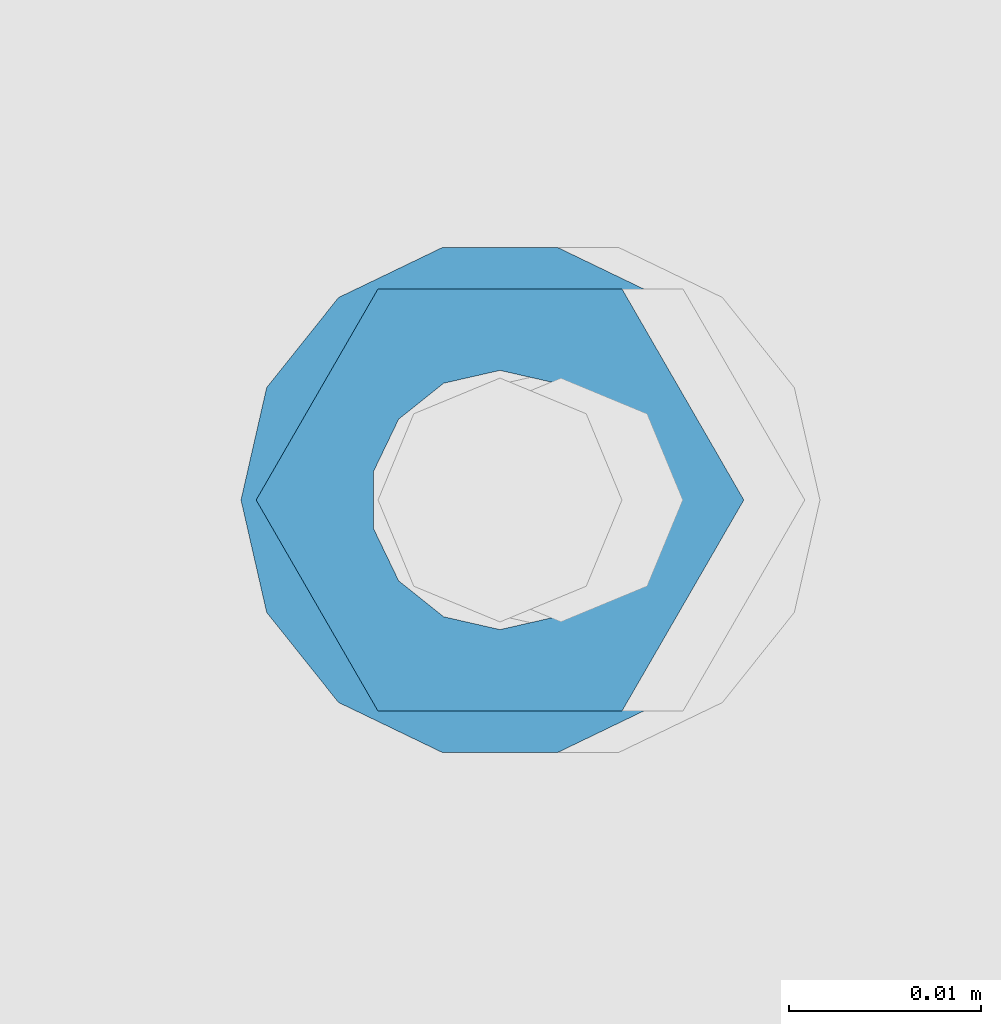
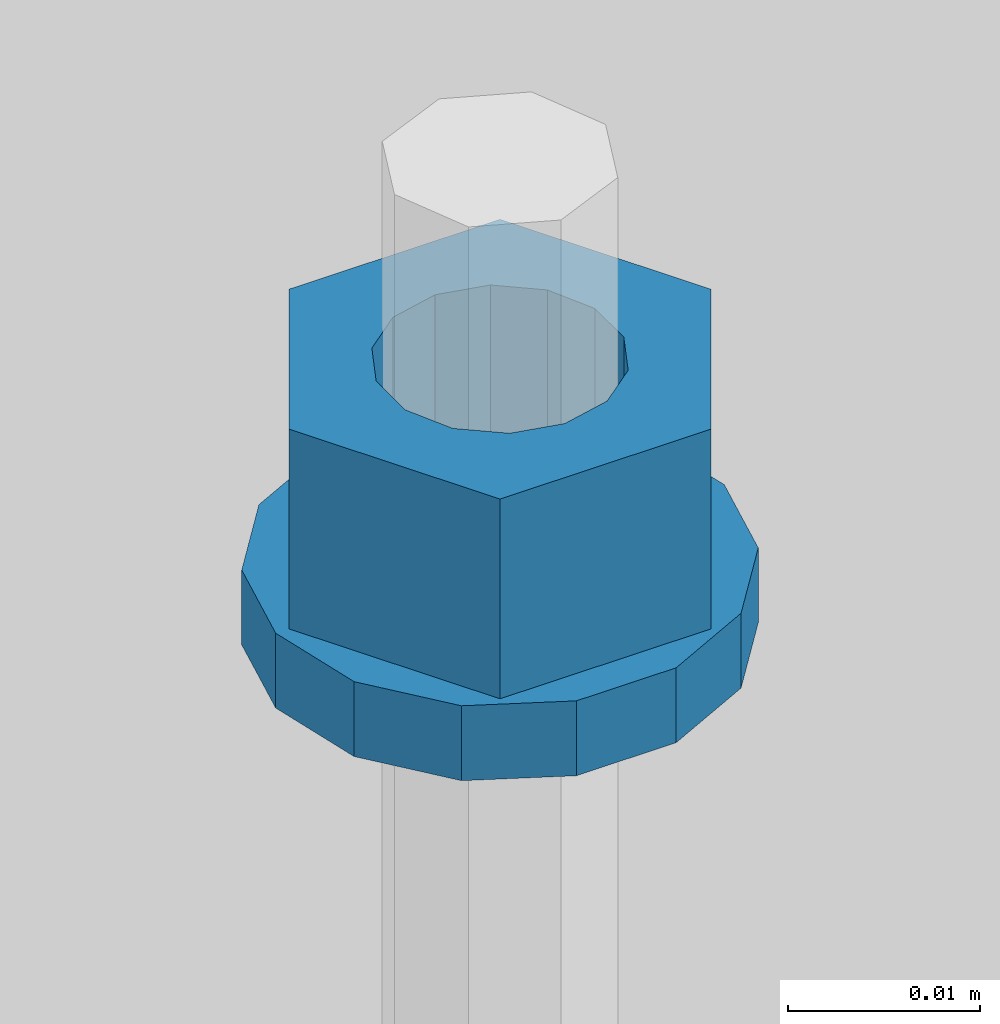
# One storey, part 669 of 1179: 2 columns, 1 element without a shape of its own.
"""IFC2X3 building model written with IfcOpenShell, lengths in millimetres."""

import ifcopenshell
import ifcopenshell.guid

model = None  # the IFC model being written
_history = None  # IfcOwnerHistory: only IFC2X3 demands one
_inside = {}  # id of a spatial element -> (the spatial element, [elements in it])
_under = {}  # id of a project, library or spatial element -> (it, [spatial elements below it])
_declared = {}  # id of a project -> (the project, [libraries it declares])
_typed = {}  # id of a type object -> (the type object, [elements of that type])
_made_of = {}  # id of a material, layer set ... -> (it, [elements and type objects made of it])


def new_model(schema):
    """Start an empty IFC model of exactly this schema.

    Asked for "IFC4X3", IfcOpenShell would pick the latest addendum, in which some entities
    have other attributes; the version numbers below select the first issue.
    IFC2X3 requires an IfcOwnerHistory on every rooted entity: one is made here for all.
    """
    global model, _history
    if schema == "IFC4X3":
        model = ifcopenshell.file(schema_version=(4, 3, 0, 0))
    else:
        model = ifcopenshell.file(schema=schema)
    _inside.clear()
    _under.clear()
    _declared.clear()
    _typed.clear()
    _made_of.clear()
    _history = None
    if model.schema == "IFC2X3":
        org = make("IfcOrganization", Name="unknown")
        user = make(
            "IfcPersonAndOrganization",
            ThePerson=make("IfcPerson", FamilyName="unknown"),
            TheOrganization=org,
        )
        app = make(
            "IfcApplication",
            ApplicationDeveloper=org,
            Version="unknown",
            ApplicationFullName="unknown",
            ApplicationIdentifier="unknown",
        )
        _history = make(
            "IfcOwnerHistory",
            OwningUser=user,
            OwningApplication=app,
            ChangeAction="ADDED",
            CreationDate=0,
        )
    return model


def make(cls, **values):
    """One entity of the class cls with the attributes given. An attribute that is None is left unset."""
    return model.create_entity(
        cls, **{name: value for name, value in values.items() if value is not None}
    )


def rooted(cls, **values):
    """An entity with a GlobalId (a new one), such as an element, a storey or a relation."""
    return make(cls, GlobalId=ifcopenshell.guid.new(), OwnerHistory=_history, **values)


def si_unit(unit_type, name, prefix=None):
    """IfcSIUnit, for example si_unit("LENGTHUNIT", "METRE", prefix="MILLI")."""
    return make("IfcSIUnit", UnitType=unit_type, Prefix=prefix, Name=name)


def assignment(units):
    """IfcUnitAssignment: the units of a project."""
    return None if units is None else make("IfcUnitAssignment", Units=units)


def point(xyz):
    """IfcCartesianPoint."""
    return None if xyz is None else make("IfcCartesianPoint", Coordinates=xyz)


def direction(xyz):
    """IfcDirection."""
    return None if xyz is None else make("IfcDirection", DirectionRatios=xyz)


def frame(location, z_axis=None, x_axis=None):
    """IfcAxis2Placement3D, a coordinate frame: its origin and axes. An axis left out is left unset."""
    return make(
        "IfcAxis2Placement3D",
        Location=point(location),
        Axis=direction(z_axis),
        RefDirection=direction(x_axis),
    )


def origin_with_axes():
    """The frame at (0, 0, 0) with the z axis (0, 0, 1) and the x axis (1, 0, 0) written out."""
    return frame((0.0, 0.0, 0.0), z_axis=(0.0, 0.0, 1.0), x_axis=(1.0, 0.0, 0.0))


def place(relative_to, where):
    """IfcLocalPlacement: puts the frame where relative to a parent placement (None: the world)."""
    return make(
        "IfcLocalPlacement", PlacementRelTo=relative_to, RelativePlacement=where
    )


def context(
    kind, dimensions, precision=None, world=None, true_north=None, identifier=None
):
    """IfcGeometricRepresentationContext, for example the 3D "Model" context."""
    return make(
        "IfcGeometricRepresentationContext",
        ContextIdentifier=identifier,
        ContextType=kind,
        CoordinateSpaceDimension=dimensions,
        Precision=precision,
        WorldCoordinateSystem=world,
        TrueNorth=true_north,
    )


def subcontext(parent, identifier, kind, view, scale=None):
    """IfcGeometricRepresentationSubContext, for example "Body" below "Model"."""
    return make(
        "IfcGeometricRepresentationSubContext",
        ContextIdentifier=identifier,
        ContextType=kind,
        ParentContext=parent,
        TargetScale=scale,
        TargetView=view,
    )


def project(units=None, contexts=None):
    """IfcProject with its units and contexts."""
    return rooted(
        "IfcProject",
        Name="project",
        RepresentationContexts=contexts,
        UnitsInContext=assignment(units),
    )


def spatial(cls, under=None, at=None, **own):
    """A site, building, storey or space (cls), placed at a placement, below another one or the project."""
    s = rooted(cls, ObjectPlacement=at, **own)
    if under is not None:
        _under.setdefault(under.id(), (under, []))[1].append(s)
    return s


def faces_of(points, faces, orient=None, outer=None):
    """IfcFace entities. A face is a list of loops; a loop is a list of indices into points, from 0.

    orient and outer hold one flag for each loop. By default every Orientation is true, the
    first loop of a face is its IfcFaceOuterBound and the others are IfcFaceBound.
    """
    made = []
    for i, loops in enumerate(faces):
        bounds = []
        for j, loop in enumerate(loops):
            is_outer = j == 0 if outer is None else outer[i][j]
            bounds.append(
                make(
                    "IfcFaceOuterBound" if is_outer else "IfcFaceBound",
                    Bound=make("IfcPolyLoop", Polygon=[points[k] for k in loop]),
                    Orientation=True if orient is None else orient[i][j],
                )
            )
        made.append(make("IfcFace", Bounds=bounds))
    return made


def faceted_brep(points, faces, orient=None, outer=None, voids=None):
    """IfcFacetedBrep: a solid bounded by flat faces; with voids (closed shells), ...WithVoids."""
    shared = [point(p) for p in points]
    hull = make("IfcClosedShell", CfsFaces=faces_of(shared, faces, orient, outer))
    if voids is None:
        return make("IfcFacetedBrep", Outer=hull)
    return make(
        "IfcFacetedBrepWithVoids",
        Outer=hull,
        Voids=[
            make(cls, CfsFaces=faces_of(shared, fs, o, b)) for cls, fs, o, b in voids
        ],
    )


def shape(context_of_items, identifier, shape_type, items):
    """IfcShapeRepresentation: the items that make up one representation, for example the "Body"."""
    return make(
        "IfcShapeRepresentation",
        ContextOfItems=context_of_items,
        RepresentationIdentifier=identifier,
        RepresentationType=shape_type,
        Items=items,
    )


def material(Name=None, Category=None):
    """IfcMaterial."""
    return make("IfcMaterial", Name=Name, Category=Category)


def made_of(thing, what):
    """Note that an element or type object is made of a material, layer set ...; save() writes the relation."""
    if what is not None:
        _made_of.setdefault(what.id(), (what, []))[1].append(thing)
    return thing


def type_object(cls, material=None, **own):
    """A type object (cls), such as IfcWallType, which elements share."""
    return made_of(rooted(cls, **own), material)


def element(
    cls,
    number,
    at=None,
    inside=None,
    cuts=None,
    type_object=None,
    material=None,
    context=None,
    identifier="Body",
    shape_type=None,
    held_by="IfcProductDefinitionShape",
    body=None,
    shapes=None,
    **own,
):
    """One element of the class cls, such as IfcWall. Its Tag is "e" and its number.

    at: its placement. inside: the storey or other place that contains it. cuts: it is an
    opening in that element (IfcRelVoidsElement). A single representation is given by context,
    identifier, shape_type and body (its items); several are given by shapes. held_by: the class
    of the entity that holds the representations. save() writes the other relations.
    """
    e = rooted(cls, Tag="e%d" % number, ObjectPlacement=at, **own)
    if body is not None:
        shapes = [shape(context, identifier, shape_type, body)]
    if shapes is not None:
        e.Representation = make(held_by, Representations=shapes)
    if inside is not None:
        _inside.setdefault(inside.id(), (inside, []))[1].append(e)
    if cuts is not None:
        rooted(
            "IfcRelVoidsElement", RelatingBuildingElement=cuts, RelatedOpeningElement=e
        )
    if type_object is not None:
        _typed.setdefault(type_object.id(), (type_object, []))[1].append(e)
    return made_of(e, material)


def aggregate(whole, parts):
    """IfcRelAggregates: a whole, such as a stair, and the parts it consists of."""
    return rooted("IfcRelAggregates", RelatingObject=whole, RelatedObjects=parts)


def save(model, path):
    """Write the relations noted so far, then the file.

    IfcRelAggregates (storeys below a building ...), IfcRelContainedInSpatialStructure (elements
    in a storey), IfcRelDefinesByType, IfcRelAssociatesMaterial and IfcRelDeclares: one each for
    every whole, place, type object, material and project.
    """
    for whole, parts in _under.values():
        aggregate(whole, parts)
    for where, things in _inside.values():
        rooted(
            "IfcRelContainedInSpatialStructure",
            RelatedElements=things,
            RelatingStructure=where,
        )
    for kind, things in _typed.values():
        rooted("IfcRelDefinesByType", RelatedObjects=things, RelatingType=kind)
    for what, things in _made_of.values():
        rooted("IfcRelAssociatesMaterial", RelatedObjects=things, RelatingMaterial=what)
    for by, libraries in _declared.values():
        rooted("IfcRelDeclares", RelatingContext=by, RelatedDefinitions=libraries)
    model.write(path)


model = new_model("IFC2X3")

# Units and contexts
model_context = context("Model", 3, precision=1e-05, world=origin_with_axes())
body_context = subcontext(model_context, "Body", "Model", "MODEL_VIEW")
ifc_project = project(units=[si_unit("LENGTHUNIT", "METRE", prefix="MILLI"), si_unit("AREAUNIT", "SQUARE_METRE"), si_unit("VOLUMEUNIT", "CUBIC_METRE"), si_unit("MASSUNIT", "GRAM", prefix="KILO"), si_unit("TIMEUNIT", "SECOND"), si_unit("PLANEANGLEUNIT", "RADIAN"), si_unit("SOLIDANGLEUNIT", "STERADIAN"), si_unit("THERMODYNAMICTEMPERATUREUNIT", "DEGREE_CELSIUS"), si_unit("LUMINOUSINTENSITYUNIT", "LUMEN")], contexts=[model_context])

# Site, building, storey
site_placement = place(None, origin_with_axes())
site = spatial("IfcSite", under=ifc_project, at=site_placement, CompositionType="ELEMENT")
building_placement = place(site_placement, origin_with_axes())
building = spatial("IfcBuilding", under=site, at=building_placement, Name="Undefined", CompositionType="ELEMENT")
storey_placement = place(building_placement, origin_with_axes())
storey = spatial("IfcBuildingStorey", under=building, at=storey_placement, Name="Undefined", CompositionType="ELEMENT", Elevation=0.0)

# Assembly, columns
assembly_placement = place(storey_placement, origin_with_axes())
assembly = element("IfcElementAssembly", 1, at=assembly_placement, inside=storey, Name="BEAM", AssemblyPlace="NOTDEFINED", PredefinedType="RIGID_FRAME")
ifc_material = material(Name="STEEL/A307")
column_type_1 = type_object("IfcColumnType", Name="1/2_WASHER", PredefinedType="NOTDEFINED")
column_1_placement = place(assembly_placement, frame((10236.1999938965, 41529.0, 4235.45), z_axis=(0.0, 1.0, 0.0), x_axis=(0.0, 0.0, 1.0)))
column_1 = element("IfcColumn", 2, at=column_1_placement, type_object=column_type_1, material=ifc_material, Name="WASHER", ObjectType="1/2_WASHER", context=body_context, shape_type="Brep", body=[
    faceted_brep([(0.0, -13.4899997711182, 0.0), (0.0, -12.1540698217868, -5.85309154138758), (4.76249999999891, -12.1540698217868, -5.85309154138758), (4.76249999999891, -13.4899997711182, 0.0), (0.0, -8.41087728436833, -10.5469065195466), (4.76249999999891, -8.41087728436833, -10.5469065195466), (0.0, -3.00180734814057, -13.1517773121896), (4.76249999999891, -3.00180734814057, -13.1517773121896), (0.0, 3.00180734814057, -13.1517773121896), (4.76249999999891, 3.00180734814057, -13.1517773121896), (0.0, 8.41087728436833, -10.5469065195466), (4.76249999999891, 8.41087728436833, -10.5469065195466), (0.0, 12.1540698217868, -5.85309154138758), (4.76249999999891, 12.1540698217868, -5.85309154138758), (0.0, 13.4899997711182, 0.0), (4.76249999999891, 13.4899997711182, 0.0), (0.0, 12.1540698217868, 5.85309154138758), (4.76249999999891, 12.1540698217868, 5.85309154138758), (0.0, 8.41087728436833, 10.5469065195466), (4.76249999999891, 8.41087728436833, 10.5469065195466), (0.0, 3.00180734814057, 13.1517773121896), (4.76249999999891, 3.00180734814057, 13.1517773121896), (0.0, -3.00180734814057, 13.1517773121896), (4.76249999999891, -3.00180734814057, 13.1517773121896), (0.0, -8.41087728436833, 10.5469065195466), (4.76249999999891, -8.41087728436833, 10.5469065195466), (0.0, -12.1540698217868, 5.85309154138758), (4.76249999999891, -12.1540698217868, 5.85309154138758), (0.0, 0.0, 6.75), (0.0, 2.9287152390425, 6.08153985834178), (4.76249999999891, 2.9287152390425, 6.08153985834178), (4.76249999999891, 0.0, 6.75), (0.0, 5.27736250665839, 4.2085561625463), (4.76249999999891, 5.27736250665839, 4.2085561625463), (0.0, 6.58076340722619, 1.50201630420543), (4.76249999999891, 6.58076340722619, 1.50201630420543), (0.0, 6.58076340722619, -1.50201630420543), (4.76249999999891, 6.58076340722619, -1.50201630420543), (0.0, 5.27736250665839, -4.2085561625463), (4.76249999999891, 5.27736250665839, -4.2085561625463), (0.0, 2.9287152390425, -6.08153985834088), (4.76249999999891, 2.9287152390425, -6.08153985834088), (0.0, 0.0, -6.75), (4.76249999999891, 0.0, -6.75), (0.0, -2.9287152390425, -6.08153985834178), (4.76249999999891, -2.9287152390425, -6.08153985834178), (0.0, -5.27736250665839, -4.2085561625463), (4.76249999999891, -5.27736250665839, -4.2085561625463), (0.0, -6.58076340722619, -1.50201630420543), (4.76249999999891, -6.58076340722619, -1.50201630420543), (0.0, -6.58076340722619, 1.50201630420543), (4.76249999999891, -6.58076340722619, 1.50201630420543), (0.0, -5.27736250665839, 4.2085561625463), (4.76249999999891, -5.27736250665839, 4.2085561625463), (0.0, -2.9287152390425, 6.08153985834088), (4.76249999999891, -2.9287152390425, 6.08153985834088)], [[[0, 1, 2, 3]], [[1, 4, 5, 2]], [[4, 6, 7, 5]], [[6, 8, 9, 7]], [[8, 10, 11, 9]], [[10, 12, 13, 11]], [[12, 14, 15, 13]], [[14, 16, 17, 15]], [[16, 18, 19, 17]], [[18, 20, 21, 19]], [[20, 22, 23, 21]], [[22, 24, 25, 23]], [[24, 26, 27, 25]], [[26, 0, 3, 27]], [[28, 29, 30, 31]], [[29, 32, 33, 30]], [[32, 34, 35, 33]], [[34, 36, 37, 35]], [[36, 38, 39, 37]], [[38, 40, 41, 39]], [[40, 42, 43, 41]], [[42, 44, 45, 43]], [[44, 46, 47, 45]], [[46, 48, 49, 47]], [[48, 50, 51, 49]], [[50, 52, 53, 51]], [[52, 54, 55, 53]], [[54, 28, 31, 55]], [[5, 7, 9, 11, 13, 15, 17, 19, 21, 23, 25, 27, 3, 2], [33, 35, 37, 39, 41, 43, 45, 47, 49, 51, 53, 55, 31, 30]], [[26, 24, 22, 20, 18, 16, 14, 12, 10, 8, 6, 4, 1, 0], [54, 52, 50, 48, 46, 44, 42, 40, 38, 36, 34, 32, 29, 28]]]),
])
column_type_2 = type_object("IfcColumnType", Name="1/2_HEAVY_HEX_NUT", PredefinedType="NOTDEFINED")
column_2_placement = place(assembly_placement, frame((10236.1999938965, 41529.0, 4240.2125), z_axis=(0.0, 1.0, 0.0), x_axis=(0.0, 0.0, 1.0)))
column_2 = element("IfcColumn", 3, at=column_2_placement, type_object=column_type_2, material=ifc_material, Name="NUT", ObjectType="1/2_HEAVY_HEX_NUT", context=body_context, shape_type="Brep", body=[
    faceted_brep([(0.0, -12.7, 0.0), (0.0, -6.34999990463257, -11.0), (12.7000000000007, -6.34999990463257, -11.0), (12.7000000000007, -12.6999998092651, 0.0), (0.0, 6.34999990463257, -11.0), (12.7000000000007, 6.34999990463257, -11.0), (0.0, 12.7, 0.0), (12.7000000000007, 12.6999998092651, 0.0), (0.0, 6.34999990463257, 11.0), (12.7000000000007, 6.34999990463257, 11.0), (0.0, -6.34999990463257, 11.0), (12.7000000000007, -6.34999990463257, 11.0), (0.0, 0.0, 6.75), (0.0, 2.9287152390425, 6.08153985834178), (12.7000000000007, 2.9287152390425, 6.08153985834178), (12.7000000000007, 0.0, 6.75), (0.0, 5.27736250665839, 4.2085561625463), (12.7000000000007, 5.27736250665839, 4.2085561625463), (0.0, 6.58076340722619, 1.50201630420543), (12.7000000000007, 6.58076340722619, 1.50201630420543), (0.0, 6.58076340722619, -1.50201630420543), (12.7000000000007, 6.58076340722619, -1.50201630420543), (0.0, 5.27736250665839, -4.2085561625463), (12.7000000000007, 5.27736250665839, -4.2085561625463), (0.0, 2.9287152390425, -6.08153985834088), (12.7000000000007, 2.9287152390425, -6.08153985834088), (0.0, 0.0, -6.75), (12.7000000000007, 0.0, -6.75), (0.0, -2.9287152390425, -6.08153985834178), (12.7000000000007, -2.9287152390425, -6.08153985834178), (0.0, -5.27736250665839, -4.2085561625463), (12.7000000000007, -5.27736250665839, -4.2085561625463), (0.0, -6.58076340722619, -1.50201630420543), (12.7000000000007, -6.58076340722619, -1.50201630420543), (0.0, -6.58076340722619, 1.50201630420543), (12.7000000000007, -6.58076340722619, 1.50201630420543), (0.0, -5.27736250665839, 4.2085561625463), (12.7000000000007, -5.27736250665839, 4.2085561625463), (0.0, -2.9287152390425, 6.08153985834088), (12.7000000000007, -2.9287152390425, 6.08153985834088)], [[[0, 1, 2, 3]], [[1, 4, 5, 2]], [[4, 6, 7, 5]], [[6, 8, 9, 7]], [[8, 10, 11, 9]], [[10, 0, 3, 11]], [[12, 13, 14, 15]], [[13, 16, 17, 14]], [[16, 18, 19, 17]], [[18, 20, 21, 19]], [[20, 22, 23, 21]], [[22, 24, 25, 23]], [[24, 26, 27, 25]], [[26, 28, 29, 27]], [[28, 30, 31, 29]], [[30, 32, 33, 31]], [[32, 34, 35, 33]], [[34, 36, 37, 35]], [[36, 38, 39, 37]], [[38, 12, 15, 39]], [[5, 7, 9, 11, 3, 2], [17, 19, 21, 23, 25, 27, 29, 31, 33, 35, 37, 39, 15, 14]], [[10, 8, 6, 4, 1, 0], [38, 36, 34, 32, 30, 28, 26, 24, 22, 20, 18, 16, 13, 12]]]),
])
aggregate(assembly, [column_1, column_2])

save(model, "model.ifc")
